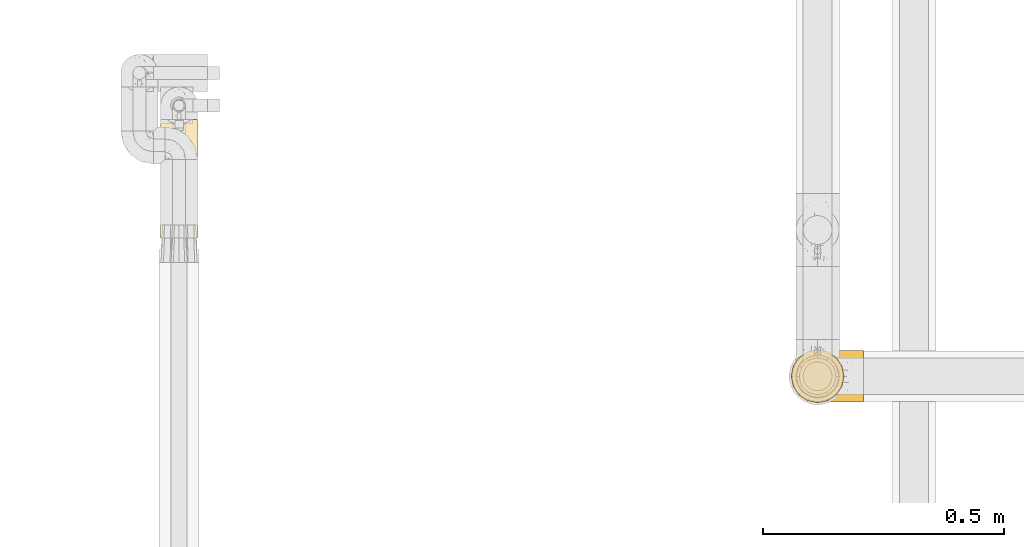
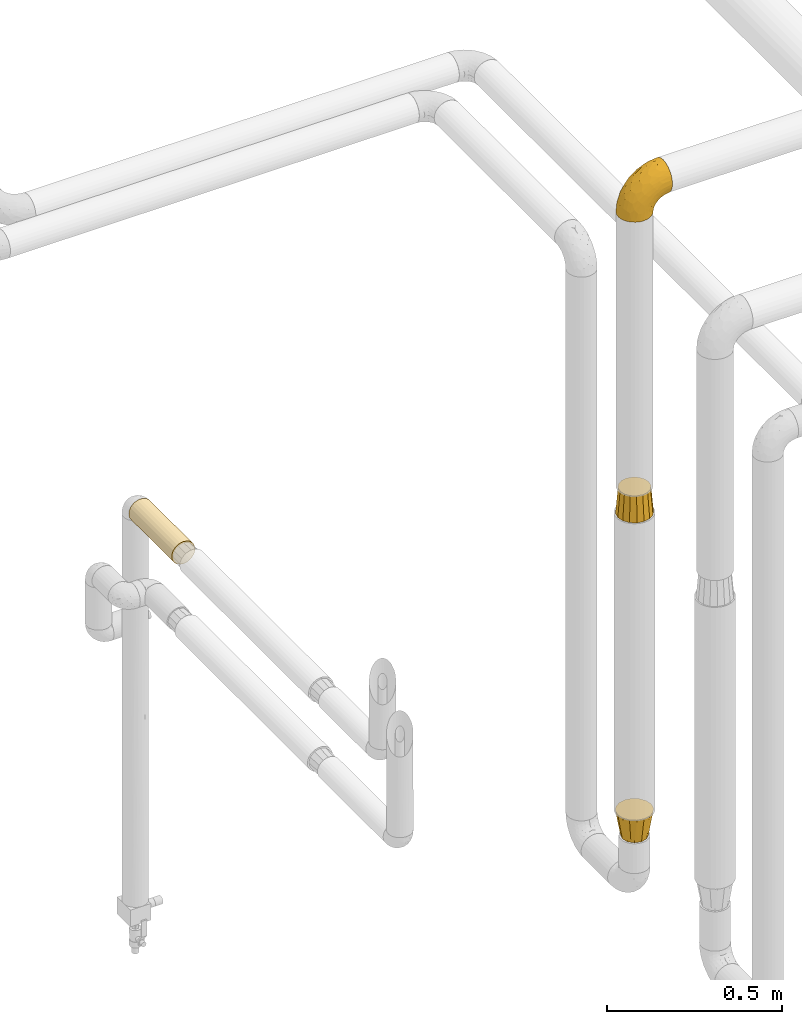
# One storey, part 109 of 827: 4 coverings.
"""IFC2X3 building model written with IfcOpenShell, lengths in millimetres."""

from ifc_helpers import new_model, entity, si_unit, converted_unit, derived_unit, direction, frame, origin, place, context, subcontext, project, spatial, faceted_brep, element, save


model = new_model("IFC2X3")

# Units and contexts
model_context = context("Model", 3, precision=0.01, world=origin(), true_north=direction((6.12303176911189e-17, 1.0)))
body_context = subcontext(model_context, "Body", "Model", "MODEL_VIEW")
ifc_project = project(units=[si_unit("LENGTHUNIT", "METRE", prefix="MILLI"), si_unit("AREAUNIT", "SQUARE_METRE"), si_unit("VOLUMEUNIT", "CUBIC_METRE"), converted_unit("PLANEANGLEUNIT", "DEGREE", entity("IfcRatioMeasure", 0.0174532925199433), si_unit("PLANEANGLEUNIT", "RADIAN"), dimensions=[0, 0, 0, 0, 0, 0, 0]), si_unit("MASSUNIT", "GRAM", prefix="KILO"), derived_unit("MASSDENSITYUNIT", [(si_unit("MASSUNIT", "GRAM", prefix="KILO"), 1), (si_unit("LENGTHUNIT", "METRE"), -3)]), derived_unit("MOMENTOFINERTIAUNIT", [(si_unit("LENGTHUNIT", "METRE"), 4)]), si_unit("TIMEUNIT", "SECOND"), si_unit("FREQUENCYUNIT", "HERTZ"), si_unit("THERMODYNAMICTEMPERATUREUNIT", "DEGREE_CELSIUS"), derived_unit("THERMALTRANSMITTANCEUNIT", [(si_unit("MASSUNIT", "GRAM", prefix="KILO"), 1), (si_unit("THERMODYNAMICTEMPERATUREUNIT", "KELVIN"), -1), (si_unit("TIMEUNIT", "SECOND"), -3)]), derived_unit("VOLUMETRICFLOWRATEUNIT", [(si_unit("LENGTHUNIT", "METRE"), 3), (si_unit("TIMEUNIT", "SECOND"), -1)]), derived_unit("MASSFLOWRATEUNIT", [(si_unit("MASSUNIT", "GRAM", prefix="KILO"), 1), (si_unit("TIMEUNIT", "SECOND"), -1)]), derived_unit("ROTATIONALFREQUENCYUNIT", [(si_unit("TIMEUNIT", "SECOND"), -1)]), si_unit("ELECTRICCURRENTUNIT", "AMPERE"), si_unit("ELECTRICVOLTAGEUNIT", "VOLT"), si_unit("POWERUNIT", "WATT"), si_unit("FORCEUNIT", "NEWTON", prefix="KILO"), si_unit("ILLUMINANCEUNIT", "LUX"), si_unit("LUMINOUSFLUXUNIT", "LUMEN"), si_unit("LUMINOUSINTENSITYUNIT", "CANDELA"), derived_unit("USERDEFINED", [(si_unit("MASSUNIT", "GRAM", prefix="KILO"), -1), (si_unit("LENGTHUNIT", "METRE"), -2), (si_unit("TIMEUNIT", "SECOND"), 3), (si_unit("LUMINOUSFLUXUNIT", "LUMEN"), 1)]), derived_unit("LINEARVELOCITYUNIT", [(si_unit("LENGTHUNIT", "METRE"), 1), (si_unit("TIMEUNIT", "SECOND"), -1)]), si_unit("PRESSUREUNIT", "PASCAL"), derived_unit("USERDEFINED", [(si_unit("LENGTHUNIT", "METRE"), -2), (si_unit("MASSUNIT", "GRAM", prefix="KILO"), 1), (si_unit("TIMEUNIT", "SECOND"), -2)]), derived_unit("LINEARFORCEUNIT", [(si_unit("MASSUNIT", "GRAM", prefix="KILO"), 1), (si_unit("LENGTHUNIT", "METRE"), 1), (si_unit("TIMEUNIT", "SECOND"), -2), (si_unit("LENGTHUNIT", "METRE"), -1)]), derived_unit("PLANARFORCEUNIT", [(si_unit("MASSUNIT", "GRAM", prefix="KILO"), 1), (si_unit("LENGTHUNIT", "METRE"), 1), (si_unit("TIMEUNIT", "SECOND"), -2), (si_unit("LENGTHUNIT", "METRE"), -2)])], contexts=[model_context])

# Site, building, storey
site_placement = place(None, origin())
site = spatial("IfcSite", under=ifc_project, at=site_placement, CompositionType="ELEMENT")
building_placement = place(site_placement, origin())
building = spatial("IfcBuilding", under=site, at=building_placement, CompositionType="ELEMENT")
storey_placement = place(building_placement, frame((0.0, 0.0, 28200.0)))
storey = spatial("IfcBuildingStorey", under=building, at=storey_placement, Name="08", CompositionType="ELEMENT", Elevation=28200.0)

# Coverings
covering_1_placement = place(storey_placement, frame((19736.27, 11546.06, 1764.58)))
element("IfcCovering", 1, at=covering_1_placement, inside=storey, Name=":ADSK_", ObjectType=":ADSK_", PredefinedType="INSULATION", context=body_context, shape_type="Brep", body=[
    faceted_brep([(20.8, 245.9, 73.25), (30.06, 245.9, 77.09), (40.0, 245.9, 78.4), (49.93, 245.9, 77.09), (59.2, 245.9, 73.25), (67.15, 245.9, 67.15), (73.25, 245.9, 59.2), (77.09, 245.9, 49.93), (78.4, 245.9, 40.0), (77.51, 245.9, 31.79), (74.9, 245.9, 23.98), (70.68, 245.9, 16.91), (65.05, 245.9, 10.9), (14.94, 245.9, 10.9), (9.31, 245.9, 16.91), (5.09, 245.9, 23.98), (2.48, 245.9, 31.79), (1.6, 245.9, 40.0), (2.9, 245.9, 49.93), (6.74, 245.9, 59.2), (12.84, 245.9, 67.15), (20.8, 0.0, 73.25), (12.84, 0.0, 67.15), (6.74, 0.0, 59.2), (2.9, 0.0, 49.93), (1.6, 0.0, 40.0), (2.9, 0.0, 30.06), (6.74, 0.0, 20.8), (12.84, 0.0, 12.84), (20.8, 0.0, 6.74), (30.06, 0.0, 2.9), (40.0, 0.0, 1.6), (49.93, 0.0, 2.9), (59.2, 0.0, 6.74), (67.15, 0.0, 12.84), (73.25, 0.0, 20.8), (77.09, 0.0, 30.06), (78.4, 0.0, 40.0), (77.09, 0.0, 49.93), (73.25, 0.0, 59.2), (67.15, 0.0, 67.15), (59.2, 0.0, 73.25), (49.93, 0.0, 77.09), (40.0, 0.0, 78.4), (30.06, 0.0, 77.09), (53.36, 239.0, 4.0), (46.78, 237.2, 2.2), (40.0, 236.6, 1.6), (59.51, 241.93, 6.92), (33.21, 237.2, 2.2), (26.63, 239.0, 4.0), (20.48, 241.93, 6.92)], [[[0, 1, 2, 3, 4, 5, 6, 7, 8, 9, 10, 11, 12, 13, 14, 15, 16, 17, 18, 19, 20]], [[21, 22, 23, 24, 25, 26, 27, 28, 29, 30, 31, 32, 33, 34, 35, 36, 37, 38, 39, 40, 41, 42, 43, 44]], [[37, 36, 9]], [[36, 35, 10]], [[11, 35, 34]], [[9, 8, 37]], [[10, 9, 36]], [[35, 11, 10]], [[34, 12, 11]], [[45, 33, 32]], [[32, 31, 46]], [[47, 46, 31]], [[48, 12, 33]], [[46, 45, 32]], [[48, 33, 45]], [[33, 12, 34]], [[49, 47, 31]], [[49, 31, 30]], [[50, 30, 29]], [[50, 49, 30]], [[13, 51, 29]], [[50, 29, 51]], [[29, 28, 13]], [[14, 28, 27]], [[15, 27, 26]], [[16, 26, 25]], [[14, 27, 15]], [[15, 26, 16]], [[25, 17, 16]], [[28, 14, 13]], [[18, 17, 25, 24]], [[19, 18, 24, 23]], [[23, 22, 20, 19]], [[1, 0, 21, 44]], [[2, 1, 44, 43]], [[22, 21, 0, 20]], [[3, 2, 43, 42]], [[4, 3, 42, 41]], [[41, 40, 5, 4]], [[7, 6, 39, 38]], [[8, 7, 38, 37]], [[40, 39, 6, 5]], [[48, 45, 46, 47, 49, 50, 51, 13, 12]]]),
])
covering_2_placement = place(storey_placement, frame((21045.41, 11205.0, 2703.4)))
element("IfcCovering", 2, at=covering_2_placement, inside=storey, Name=":ADSK_", ObjectType=":ADSK_", PredefinedType="INSULATION", context=body_context, shape_type="Brep", body=[
    faceted_brep([(2.92, 42.85, 1.6), (1.6, 54.65, 1.6), (2.93, 66.46, 1.6), (6.85, 77.67, 1.6), (13.18, 87.73, 1.6), (21.58, 96.13, 1.6), (31.64, 102.45, 1.6), (42.85, 106.37, 1.6), (54.65, 107.7, 1.6), (66.46, 106.36, 1.6), (77.67, 102.44, 1.6), (87.73, 96.11, 1.6), (96.13, 87.71, 1.6), (102.45, 77.65, 1.6), (106.37, 66.44, 1.6), (107.7, 54.65, 1.6), (106.36, 42.84, 1.6), (102.44, 31.62, 1.6), (96.11, 21.56, 1.6), (87.71, 13.16, 1.6), (77.65, 6.84, 1.6), (66.44, 2.92, 1.6), (54.65, 1.6, 1.6), (42.84, 2.93, 1.6), (31.62, 6.85, 1.6), (21.56, 13.18, 1.6), (13.16, 21.58, 1.6), (6.84, 31.64, 1.6), (149.65, 68.38, 45.35), (149.65, 81.17, 50.65), (149.65, 92.16, 59.08), (149.65, 100.59, 70.07), (149.65, 105.89, 82.86), (149.65, 107.7, 96.6), (149.65, 105.89, 110.33), (149.65, 100.59, 123.12), (149.65, 92.16, 134.11), (149.65, 81.17, 142.54), (149.65, 68.38, 147.84), (149.65, 54.65, 149.65), (149.65, 40.91, 147.84), (149.65, 28.12, 142.54), (149.65, 17.13, 134.11), (149.65, 8.7, 123.12), (149.65, 3.4, 110.33), (149.65, 1.6, 96.6), (149.65, 3.4, 82.86), (149.65, 8.7, 70.07), (149.65, 17.13, 59.08), (149.65, 28.12, 50.65), (149.65, 40.91, 45.35), (149.65, 54.65, 43.55), (123.27, 23.76, 137.19), (114.15, 35.87, 141.79), (92.97, 25.52, 128.89), (124.11, 45.07, 146.54), (111.33, 54.65, 144.6), (42.13, 12.57, 69.77), (56.83, 15.93, 94.41), (40.31, 24.82, 87.22), (61.55, 37.92, 117.2), (75.62, 54.65, 129.81), (44.96, 54.65, 106.28), (91.12, 5.82, 101.45), (109.83, 8.38, 115.81), (88.02, 10.19, 109.14), (119.19, 3.86, 107.65), (99.11, 2.5, 93.36), (27.97, 19.48, 59.44), (21.92, 29.7, 63.23), (12.94, 28.0, 35.59), (88.29, 35.28, 132.3), (95.35, 45.15, 138.41), (113.84, 14.54, 126.28), (6.64, 54.65, 39.91), (8.58, 38.55, 37.44), (33.39, 40.99, 90.35), (17.23, 43.24, 65.0), (61.99, 8.56, 85.4), (47.9, 2.51, 26.66), (37.72, 5.69, 29.88), (93.81, 1.6, 78.45), (107.05, 1.6, 85.2), (120.29, 1.6, 91.95), (73.26, 3.22, 77.98), (18.58, 18.7, 29.55), (29.72, 11.86, 41.42), (64.31, 24.78, 111.13), (82.84, 15.99, 114.67), (72.79, 1.6, 57.43), (83.3, 1.6, 67.94), (56.71, 1.6, 14.64), (59.29, 1.6, 30.95), (57.88, 2.5, 52.13), (66.04, 1.6, 44.19), (49.8, 5.82, 60.12), (21.43, 54.65, 75.62), (134.97, 1.6, 94.27), (108.79, 32.3, 24.59), (110.84, 25.01, 34.69), (101.53, 18.18, 31.15), (111.84, 3.03, 75.18), (119.98, 6.69, 67.55), (123.54, 3.21, 79.36), (134.54, 2.73, 84.32), (80.57, 3.93, 40.81), (69.55, 2.55, 29.93), (134.56, 7.7, 70.24), (128.67, 54.65, 37.93), (136.98, 54.65, 40.15), (133.56, 41.58, 42.1), (131.66, 17.93, 55.38), (117.75, 14.97, 52.17), (118.23, 22.2, 44.32), (110.55, 43.45, 19.85), (111.09, 54.65, 14.26), (113.32, 54.65, 22.57), (120.2, 40.37, 34.17), (105.95, 8.47, 54.85), (127.69, 29.46, 44.63), (139.88, 32.17, 47.52), (92.14, 3.39, 59.1), (93.82, 7.76, 44.11), (82.28, 2.57, 53.21), (130.86, 11.54, 62.86), (78.78, 6.21, 20.58), (67.58, 2.9, 15.79), (90.58, 11.19, 27.67), (90.23, 14.27, 13.49), (99.39, 22.4, 18.04), (105.17, 34.87, 12.44), (120.99, 54.65, 30.25), (104.59, 4.01, 66.71), (108.24, 16.42, 42.52), (131.66, 91.36, 55.38), (78.8, 103.07, 20.57), (133.57, 67.71, 42.11), (72.79, 107.7, 57.43), (82.27, 106.72, 53.22), (80.59, 105.35, 40.81), (110.55, 65.83, 19.85), (108.79, 76.97, 24.58), (120.2, 68.91, 34.16), (108.25, 92.85, 42.5), (106.06, 100.82, 54.93), (117.78, 94.28, 52.13), (90.6, 98.08, 27.66), (93.87, 101.51, 44.12), (93.81, 107.7, 78.45), (107.05, 107.7, 85.2), (111.89, 106.25, 75.17), (134.97, 107.7, 94.27), (134.54, 106.56, 84.32), (59.29, 107.7, 30.95), (66.04, 107.7, 44.19), (69.56, 106.74, 29.98), (104.56, 105.31, 66.78), (119.98, 102.6, 67.55), (134.56, 101.59, 70.24), (123.54, 106.08, 79.36), (90.25, 95.01, 13.48), (99.4, 86.87, 18.03), (110.83, 84.27, 34.66), (101.52, 91.11, 31.14), (105.18, 74.4, 12.43), (56.71, 107.7, 14.64), (139.89, 77.12, 47.52), (118.22, 87.06, 44.28), (67.6, 106.38, 15.8), (130.86, 97.75, 62.86), (83.3, 107.7, 67.94), (127.71, 79.83, 44.64), (92.12, 105.91, 59.12), (120.29, 107.7, 91.95), (92.97, 83.77, 128.89), (123.27, 85.53, 137.19), (113.84, 94.75, 126.28), (109.83, 100.91, 115.81), (124.03, 64.22, 146.53), (114.15, 73.42, 141.79), (98.04, 64.15, 139.45), (99.11, 106.79, 93.36), (47.9, 106.79, 26.67), (37.74, 103.61, 29.87), (49.8, 103.47, 60.12), (56.83, 93.36, 94.41), (42.16, 96.75, 69.76), (40.3, 84.48, 87.19), (57.88, 106.79, 52.13), (73.26, 106.07, 77.98), (119.19, 105.43, 107.65), (86.61, 73.44, 131.74), (27.99, 89.82, 59.44), (18.59, 90.61, 29.54), (21.92, 79.61, 63.2), (11.28, 81.34, 27.9), (33.39, 68.3, 90.35), (61.55, 71.37, 117.2), (29.73, 97.44, 41.39), (88.01, 99.1, 109.14), (62.08, 100.74, 85.46), (8.58, 70.76, 37.43), (82.84, 93.3, 114.67), (64.3, 84.5, 111.12), (91.12, 103.47, 101.45), (18.05, 68.73, 65.16)], [[[0, 1, 2, 3, 4, 5, 6, 7, 8, 9, 10, 11, 12, 13, 14, 15, 16, 17, 18, 19, 20, 21, 22, 23, 24, 25, 26, 27]], [[28, 29, 30, 31, 32, 33, 34, 35, 36, 37, 38, 39, 40, 41, 42, 43, 44, 45, 46, 47, 48, 49, 50, 51]], [[52, 53, 54]], [[55, 39, 56]], [[57, 58, 59]], [[60, 61, 62]], [[63, 64, 65]], [[66, 63, 67]], [[68, 69, 70]], [[53, 71, 54]], [[41, 40, 53]], [[53, 72, 71]], [[73, 42, 52]], [[42, 41, 52]], [[74, 0, 75]], [[69, 76, 77]], [[43, 73, 64]], [[45, 44, 66]], [[57, 78, 58]], [[23, 79, 80]], [[67, 81, 82, 83]], [[67, 84, 81]], [[24, 23, 80]], [[25, 85, 26]], [[86, 85, 25]], [[42, 73, 43]], [[0, 27, 75]], [[25, 24, 86]], [[70, 26, 85]], [[0, 74, 1]], [[68, 85, 86]], [[66, 64, 63]], [[60, 59, 87]], [[54, 87, 88]], [[76, 60, 62]], [[84, 89, 90, 81]], [[79, 22, 91, 92]], [[77, 74, 75]], [[93, 92, 94, 89]], [[80, 86, 24]], [[40, 55, 53]], [[76, 59, 60]], [[93, 84, 95]], [[76, 62, 96]], [[55, 72, 53]], [[70, 27, 26]], [[75, 70, 69]], [[78, 84, 63]], [[93, 79, 92]], [[95, 86, 80]], [[77, 76, 96]], [[59, 69, 68]], [[57, 68, 86]], [[68, 57, 59]], [[59, 58, 87]], [[76, 69, 59]], [[88, 87, 58]], [[87, 54, 71]], [[86, 95, 57]], [[78, 57, 95]], [[84, 78, 95]], [[78, 63, 65]], [[58, 78, 65]], [[54, 88, 73]], [[84, 93, 89]], [[79, 95, 80]], [[79, 93, 95]], [[22, 79, 23]], [[66, 83, 97, 45]], [[84, 67, 63]], [[83, 66, 67]], [[64, 44, 43]], [[64, 66, 44]], [[65, 73, 88]], [[53, 52, 41]], [[73, 52, 54]], [[73, 65, 64]], [[65, 88, 58]], [[39, 55, 40]], [[72, 55, 56]], [[56, 61, 72]], [[60, 72, 61]], [[72, 60, 71]], [[87, 71, 60]], [[27, 70, 75]], [[68, 70, 85]], [[74, 77, 96]], [[69, 77, 75]], [[98, 99, 100]], [[46, 45, 97]], [[101, 102, 103]], [[103, 104, 83]], [[105, 94, 106]], [[107, 103, 102]], [[108, 109, 51, 110]], [[111, 112, 113]], [[114, 115, 116]], [[47, 104, 107]], [[110, 117, 108]], [[49, 48, 111]], [[102, 118, 112]], [[119, 120, 111]], [[50, 49, 120]], [[121, 122, 118]], [[105, 123, 89]], [[124, 48, 107]], [[20, 19, 125]], [[121, 81, 90]], [[117, 119, 99]], [[21, 20, 126]], [[22, 21, 91]], [[105, 125, 127]], [[110, 51, 50]], [[19, 128, 125]], [[16, 15, 115]], [[129, 98, 100]], [[126, 91, 21]], [[128, 129, 127]], [[122, 123, 105]], [[114, 117, 98]], [[17, 16, 130]], [[18, 128, 19]], [[129, 18, 17]], [[125, 106, 126]], [[115, 114, 16]], [[130, 129, 17]], [[114, 98, 130]], [[117, 116, 131, 108]], [[99, 119, 113]], [[122, 121, 123]], [[92, 126, 106]], [[105, 127, 122]], [[132, 121, 118]], [[114, 130, 16]], [[129, 130, 98]], [[50, 120, 110]], [[129, 128, 18]], [[125, 128, 127]], [[125, 126, 20]], [[91, 126, 92]], [[105, 89, 94]], [[105, 106, 125]], [[94, 92, 106]], [[100, 122, 127]], [[118, 122, 133]], [[112, 118, 133]], [[132, 118, 102]], [[132, 102, 101]], [[81, 121, 132]], [[82, 103, 83]], [[132, 101, 81]], [[104, 47, 46]], [[124, 107, 102]], [[48, 47, 107]], [[113, 112, 133]], [[112, 111, 124]], [[99, 113, 133]], [[111, 113, 119]], [[99, 133, 100]], [[117, 99, 98]], [[122, 100, 133]], [[127, 129, 100]], [[103, 82, 101]], [[81, 101, 82]], [[112, 124, 102]], [[48, 124, 111]], [[104, 103, 107]], [[46, 97, 104]], [[111, 120, 49]], [[83, 104, 97]], [[110, 120, 119]], [[117, 110, 119]], [[116, 117, 114]], [[89, 123, 90]], [[90, 123, 121]], [[30, 29, 134]], [[11, 10, 135]], [[51, 109, 108, 136]], [[137, 138, 139]], [[140, 141, 142]], [[143, 144, 145]], [[146, 139, 147]], [[148, 149, 150]], [[151, 32, 152]], [[153, 154, 155]], [[156, 150, 157]], [[158, 157, 159]], [[108, 142, 136]], [[31, 158, 152]], [[160, 161, 12]], [[162, 163, 143]], [[140, 142, 116]], [[142, 141, 162]], [[14, 164, 140]], [[14, 140, 115]], [[9, 8, 165]], [[160, 12, 11]], [[141, 164, 161]], [[13, 12, 161]], [[14, 115, 15]], [[28, 166, 29]], [[135, 139, 146]], [[141, 163, 162]], [[135, 146, 160]], [[143, 167, 162]], [[29, 166, 134]], [[116, 142, 108, 131]], [[165, 153, 168]], [[10, 9, 168]], [[168, 135, 10]], [[138, 147, 139]], [[158, 169, 157]], [[14, 13, 164]], [[116, 115, 140]], [[145, 167, 143]], [[135, 160, 11]], [[168, 153, 155]], [[138, 137, 170]], [[157, 144, 156]], [[147, 144, 143]], [[161, 164, 13]], [[140, 164, 141]], [[142, 171, 136]], [[136, 171, 166]], [[161, 160, 146]], [[165, 168, 9]], [[155, 139, 135]], [[139, 154, 137]], [[168, 155, 135]], [[139, 155, 154]], [[144, 147, 172]], [[163, 147, 143]], [[156, 144, 172]], [[157, 169, 145]], [[172, 148, 156]], [[173, 159, 149]], [[159, 157, 150]], [[152, 159, 173]], [[159, 152, 158]], [[31, 30, 158]], [[169, 30, 134]], [[157, 145, 144]], [[167, 134, 171]], [[134, 167, 145]], [[171, 142, 162]], [[162, 167, 171]], [[163, 141, 161]], [[161, 146, 163]], [[147, 163, 146]], [[148, 150, 156]], [[149, 159, 150]], [[30, 169, 158]], [[145, 169, 134]], [[151, 33, 32]], [[31, 152, 32]], [[152, 173, 151]], [[28, 51, 136]], [[134, 166, 171]], [[28, 136, 166]], [[138, 170, 172]], [[147, 138, 172]], [[148, 172, 170]], [[174, 175, 176]], [[35, 34, 177]], [[178, 179, 180]], [[181, 173, 149, 148]], [[182, 183, 184]], [[185, 186, 187]], [[188, 189, 137]], [[190, 33, 151, 173]], [[191, 179, 174]], [[34, 190, 177]], [[39, 38, 178]], [[192, 193, 194]], [[4, 3, 195]], [[175, 179, 37]], [[38, 37, 179]], [[35, 176, 36]], [[196, 62, 197]], [[181, 190, 173]], [[37, 36, 175]], [[183, 6, 198]], [[189, 148, 170, 137]], [[185, 199, 200]], [[3, 2, 201]], [[202, 185, 203]], [[8, 7, 182]], [[200, 184, 186]], [[183, 7, 6]], [[181, 189, 204]], [[200, 189, 184]], [[5, 198, 6]], [[187, 203, 185]], [[195, 3, 201]], [[205, 196, 194]], [[62, 61, 197]], [[186, 198, 192]], [[180, 179, 191]], [[2, 1, 74]], [[198, 193, 192]], [[193, 5, 4]], [[194, 193, 195]], [[2, 74, 201]], [[5, 193, 198]], [[205, 74, 96]], [[188, 137, 154, 153]], [[62, 196, 96]], [[56, 178, 180]], [[198, 184, 183]], [[184, 188, 182]], [[203, 197, 191]], [[205, 194, 201]], [[187, 192, 194]], [[192, 187, 186]], [[194, 196, 187]], [[197, 187, 196]], [[197, 203, 187]], [[202, 174, 176]], [[200, 186, 185]], [[184, 198, 186]], [[199, 185, 202]], [[189, 200, 204]], [[174, 202, 203]], [[176, 177, 199]], [[189, 181, 148]], [[190, 181, 204]], [[190, 204, 177]], [[190, 34, 33]], [[188, 153, 182]], [[189, 188, 184]], [[182, 153, 165, 8]], [[183, 182, 7]], [[199, 177, 204]], [[35, 177, 176]], [[176, 175, 36]], [[179, 175, 174]], [[200, 199, 204]], [[176, 199, 202]], [[203, 191, 174]], [[180, 197, 61]], [[197, 180, 191]], [[61, 56, 180]], [[39, 178, 56]], [[38, 179, 178]], [[194, 195, 201]], [[4, 195, 193]], [[74, 205, 201]], [[96, 196, 205]]]),
])
covering_3_placement = place(storey_placement, frame((21043.46, 11203.05, 1656.76)))
element("IfcCovering", 3, at=covering_3_placement, inside=storey, Name=":ADSK_", ObjectType=":ADSK_", PredefinedType="INSULATION", context=body_context, shape_type="Brep", body=[
    faceted_brep([(107.41, 77.64, 0.0), (108.99, 69.69, 0.0), (111.6, 56.6, 0.0), (108.99, 43.51, 0.0), (107.41, 35.55, 0.0), (101.45, 26.63, 0.0), (95.49, 17.7, 0.0), (86.56, 11.74, 0.0), (77.64, 5.78, 0.0), (69.69, 4.2, 0.0), (56.6, 1.6, 0.0), (43.51, 4.2, 0.0), (35.55, 5.78, 0.0), (26.63, 11.74, 0.0), (17.7, 17.7, 0.0), (11.74, 26.63, 0.0), (5.78, 35.55, 0.0), (4.2, 43.51, 0.0), (1.6, 56.6, 0.0), (4.2, 69.69, 0.0), (5.78, 77.64, 0.0), (11.74, 86.56, 0.0), (17.7, 95.49, 0.0), (26.63, 101.45, 0.0), (35.55, 107.41, 0.0), (43.51, 108.99, 0.0), (56.6, 111.6, 0.0), (69.69, 108.99, 0.0), (77.64, 107.41, 0.0), (86.56, 101.45, 0.0), (95.49, 95.49, 0.0), (101.45, 86.56, 0.0), (104.1, 56.6, 89.0), (102.29, 65.68, 89.0), (100.48, 74.77, 89.0), (95.33, 82.48, 89.0), (90.18, 90.18, 89.0), (82.48, 95.33, 89.0), (74.77, 100.48, 89.0), (65.68, 102.29, 89.0), (56.6, 104.1, 89.0), (47.51, 102.29, 89.0), (38.42, 100.48, 89.0), (30.71, 95.33, 89.0), (23.01, 90.18, 89.0), (17.86, 82.48, 89.0), (12.71, 74.77, 89.0), (10.9, 65.68, 89.0), (9.1, 56.6, 89.0), (10.9, 47.51, 89.0), (12.71, 38.42, 89.0), (17.86, 30.71, 89.0), (23.01, 23.01, 89.0), (30.71, 17.86, 89.0), (38.42, 12.71, 89.0), (47.51, 10.9, 89.0), (56.6, 9.1, 89.0), (65.68, 10.9, 89.0), (74.77, 12.71, 89.0), (82.48, 17.86, 89.0), (90.18, 23.01, 89.0), (95.33, 30.71, 89.0), (100.48, 38.42, 89.0), (102.29, 47.51, 89.0)], [[[0, 1, 2, 3, 4, 5, 6, 7, 8, 9, 10, 11, 12, 13, 14, 15, 16, 17, 18, 19, 20, 21, 22, 23, 24, 25, 26, 27, 28, 29, 30, 31]], [[32, 33, 34, 35, 36, 37, 38, 39, 40, 41, 42, 43, 44, 45, 46, 47, 48, 49, 50, 51, 52, 53, 54, 55, 56, 57, 58, 59, 60, 61, 62, 63]], [[54, 12, 11, 10, 56, 55]], [[52, 14, 13, 12, 54, 53]], [[50, 16, 15, 14, 52, 51]], [[49, 48, 18, 17, 16, 50]], [[46, 20, 19, 18, 48, 47]], [[44, 22, 21, 20, 46, 45]], [[42, 24, 23, 22, 44, 43]], [[41, 40, 26, 25, 24, 42]], [[38, 28, 27, 26, 40, 39]], [[36, 30, 29, 28, 38, 37]], [[34, 0, 31, 30, 36, 35]], [[33, 32, 2, 1, 0, 34]], [[62, 4, 3, 2, 32, 63]], [[60, 6, 5, 4, 62, 61]], [[58, 8, 7, 6, 60, 59]], [[57, 56, 10, 9, 8, 58]]]),
])
covering_4_placement = place(storey_placement, frame((21043.46, 11203.05, 530.0)))
element("IfcCovering", 4, at=covering_4_placement, inside=storey, Name=":ADSK_", ObjectType=":ADSK_", PredefinedType="INSULATION", context=body_context, shape_type="Brep", body=[
    faceted_brep([(91.24, 76.6, 0.0), (93.92, 66.6, 0.0), (96.6, 56.6, 0.0), (93.92, 46.6, 0.0), (91.24, 36.6, 0.0), (83.92, 29.27, 0.0), (76.6, 21.95, 0.0), (66.6, 19.27, 0.0), (56.6, 16.6, 0.0), (46.6, 19.27, 0.0), (36.6, 21.95, 0.0), (29.27, 29.27, 0.0), (21.95, 36.6, 0.0), (19.27, 46.6, 0.0), (16.6, 56.6, 0.0), (19.27, 66.6, 0.0), (21.95, 76.6, 0.0), (29.27, 83.92, 0.0), (36.6, 91.24, 0.0), (46.6, 93.92, 0.0), (56.6, 96.6, 0.0), (66.6, 93.92, 0.0), (76.6, 91.24, 0.0), (83.92, 83.92, 0.0), (77.64, 107.41, 89.0), (67.12, 109.5, 89.0), (56.6, 111.6, 89.0), (46.07, 109.5, 89.0), (35.55, 107.41, 89.0), (26.63, 101.45, 89.0), (17.7, 95.49, 89.0), (11.74, 86.56, 89.0), (5.78, 77.64, 89.0), (3.69, 67.12, 89.0), (1.6, 56.6, 89.0), (3.69, 46.07, 89.0), (5.78, 35.55, 89.0), (11.74, 26.63, 89.0), (17.7, 17.7, 89.0), (26.63, 11.74, 89.0), (35.55, 5.78, 89.0), (46.07, 3.69, 89.0), (56.6, 1.6, 89.0), (67.12, 3.69, 89.0), (77.64, 5.78, 89.0), (86.56, 11.74, 89.0), (95.49, 17.7, 89.0), (101.45, 26.63, 89.0), (107.41, 35.55, 89.0), (109.5, 46.07, 89.0), (111.6, 56.6, 89.0), (109.5, 67.12, 89.0), (107.41, 77.64, 89.0), (101.45, 86.56, 89.0), (95.49, 95.49, 89.0), (86.56, 101.45, 89.0)], [[[0, 1, 2, 3, 4, 5, 6, 7, 8, 9, 10, 11, 12, 13, 14, 15, 16, 17, 18, 19, 20, 21, 22, 23]], [[24, 25, 26, 27, 28, 29, 30, 31, 32, 33, 34, 35, 36, 37, 38, 39, 40, 41, 42, 43, 44, 45, 46, 47, 48, 49, 50, 51, 52, 53, 54, 55]], [[35, 34, 14]], [[10, 40, 39]], [[37, 36, 12]], [[37, 12, 11]], [[10, 39, 11]], [[37, 11, 38]], [[41, 40, 9]], [[14, 13, 35]], [[39, 38, 11]], [[8, 41, 9]], [[13, 12, 36]], [[41, 8, 42]], [[40, 10, 9]], [[13, 36, 35]], [[27, 26, 20]], [[16, 32, 31]], [[29, 28, 18]], [[29, 18, 17]], [[16, 31, 17]], [[29, 17, 30]], [[33, 32, 15]], [[20, 19, 27]], [[31, 30, 17]], [[14, 33, 15]], [[19, 18, 28]], [[33, 14, 34]], [[32, 16, 15]], [[19, 28, 27]], [[51, 50, 2]], [[22, 24, 55]], [[53, 52, 0]], [[53, 0, 23]], [[22, 55, 23]], [[53, 23, 54]], [[25, 24, 21]], [[2, 1, 51]], [[55, 54, 23]], [[20, 25, 21]], [[1, 0, 52]], [[25, 20, 26]], [[24, 22, 21]], [[1, 52, 51]], [[43, 42, 8]], [[4, 48, 47]], [[45, 44, 6]], [[45, 6, 5]], [[4, 47, 5]], [[45, 5, 46]], [[49, 48, 3]], [[8, 7, 43]], [[47, 46, 5]], [[2, 49, 3]], [[7, 6, 44]], [[49, 2, 50]], [[48, 4, 3]], [[7, 44, 43]]]),
])

save(model, "model.ifc")
